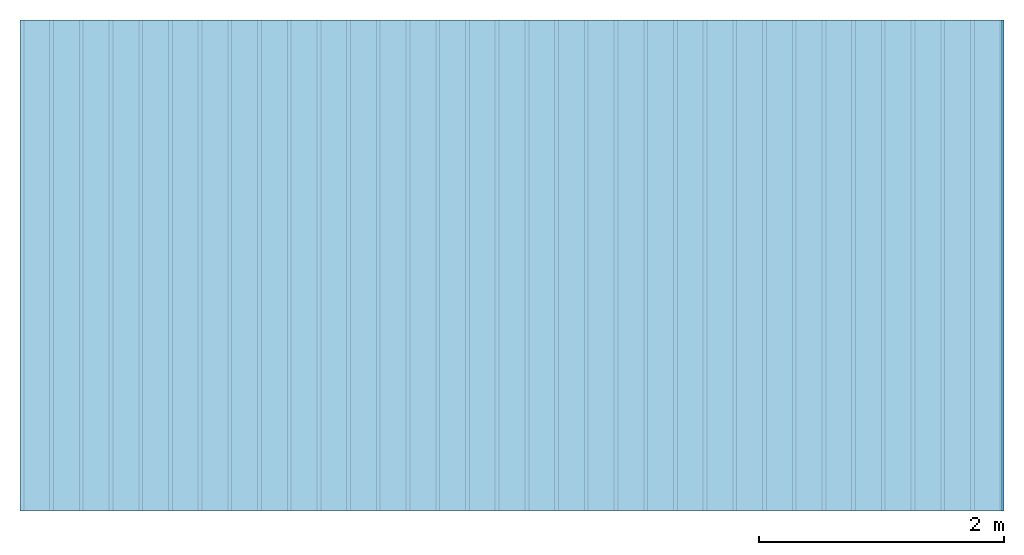
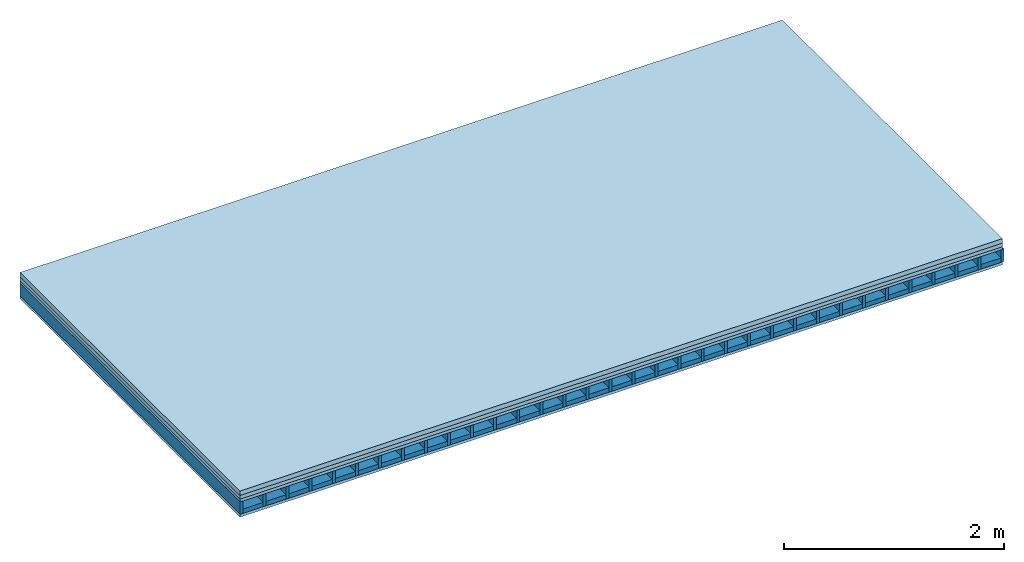
# One storey: 4 plates, 2 members, 1 element without a shape of its own.
"""IFC4 building model written with IfcOpenShell, lengths in metres."""

from ifc_helpers import new_model, si_unit, derived_unit, direction, frame, frame_2d, origin, origin_with_axes, place, context, project, spatial, rectangle, extrude, material, layer, layer_set, type_object, element, aggregate, save


model = new_model("IFC4")

# Units and contexts
plan_context = context("Plan", 3, precision=1e-05, world=origin(), true_north=direction((0.0, 1.0)))
model_context = context("Model", 3, precision=1e-05, world=origin(), true_north=direction((0.0, 1.0)))
ifc_project = project(units=[si_unit("LENGTHUNIT", "METRE"), derived_unit("SOUNDPRESSUREUNIT", [(si_unit("PRESSUREUNIT", "PASCAL", prefix="MICRO"), 0)]), si_unit("ENERGYUNIT", "JOULE", prefix="MEGA"), si_unit("MASSUNIT", "GRAM", prefix="KILO"), derived_unit("THERMALTRANSMITTANCEUNIT", [(si_unit("POWERUNIT", "WATT"), 1), (si_unit("AREAUNIT", "SQUARE_METRE"), -1), (si_unit("THERMODYNAMICTEMPERATUREUNIT", "KELVIN"), -1)]), derived_unit("AREADENSITYUNIT", [(si_unit("MASSUNIT", "GRAM", prefix="KILO"), 1), (si_unit("AREAUNIT", "SQUARE_METRE"), -1)]), derived_unit("USERDEFINED", [(si_unit("ENERGYUNIT", "JOULE", prefix="MEGA"), 1), (si_unit("AREAUNIT", "SQUARE_METRE"), -1)])], contexts=[plan_context, model_context])

# Site, building, storey
site = spatial("IfcSite", under=ifc_project)
building_placement = place(None, origin())
building = spatial("IfcBuilding", under=site, at=building_placement)
storey_placement = place(building_placement, origin())
storey = spatial("IfcBuildingStorey", under=building, at=storey_placement)

# Slab, members, plates
ifc_material_1 = material(Name="Cement screed", Category="04.006")
ifc_layer_1 = layer(ifc_material_1, 0.05, Name="On-material")
ifc_material_2 = material(Name="EP1, 40/35mm")
ifc_layer_2 = layer(ifc_material_2, 0.04, Name="Impact sound insulation")
ifc_material_3 = material(Name="surface element sheathing above")
ifc_layer_3 = layer(ifc_material_3, 0.031, Name="Sub-floor")
ifc_layer_4 = layer(None, 0.138, Name="Supporting structure")
ifc_material_4 = material(Name="surface element sheathing below")
ifc_layer_5 = layer(ifc_material_4, 0.031, Name="Lower layer 1")
ifc_layer_set = layer_set([ifc_layer_1, ifc_layer_2, ifc_layer_3, ifc_layer_4, ifc_layer_5])
slab_type = type_object("IfcSlabType", Name="A2705", PredefinedType="NOTDEFINED", material=ifc_layer_set)
slab_placement = place(None, frame((0.0, 0.0, 0.0), z_axis=(0.0, 0.0, -1.0), x_axis=(1.0, 0.0, 0.0)))
slab = element("IfcSlab", 1, at=slab_placement, inside=storey, type_object=slab_type, material=ifc_layer_set, Name="Slab #1")
ifc_material_5 = material(Name="surface element LFE")
member_1_placement = place(slab_placement, origin())
member_1 = element("IfcMember", 2, at=member_1_placement, material=ifc_material_5, Name="Supporting structure", context=plan_context, shape_type="SweptSolid", body=[
    extrude(rectangle(XDim=0.031, YDim=0.138, at=frame_2d((0.0155, 0.069), x_axis=(1.0, 0.0))), frame((0.0, 4.0, 0.121), z_axis=(0.0, -1.0, 0.0), x_axis=(1.0, 0.0, 0.0)), (0.0, 0.0, 1.0), 4.0),
    extrude(rectangle(XDim=0.031, YDim=0.138, at=frame_2d((0.0155, 0.069), x_axis=(1.0, 0.0))), frame((0.242, 4.0, 0.121), z_axis=(0.0, -1.0, 0.0), x_axis=(1.0, 0.0, 0.0)), (0.0, 0.0, 1.0), 4.0),
    extrude(rectangle(XDim=0.031, YDim=0.138, at=frame_2d((0.0155, 0.069), x_axis=(1.0, 0.0))), frame((0.484, 4.0, 0.121), z_axis=(0.0, -1.0, 0.0), x_axis=(1.0, 0.0, 0.0)), (0.0, 0.0, 1.0), 4.0),
    extrude(rectangle(XDim=0.031, YDim=0.138, at=frame_2d((0.0155, 0.069), x_axis=(1.0, 0.0))), frame((0.726, 4.0, 0.121), z_axis=(0.0, -1.0, 0.0), x_axis=(1.0, 0.0, 0.0)), (0.0, 0.0, 1.0), 4.0),
    extrude(rectangle(XDim=0.031, YDim=0.138, at=frame_2d((0.0155, 0.069), x_axis=(1.0, 0.0))), frame((0.968, 4.0, 0.121), z_axis=(0.0, -1.0, 0.0), x_axis=(1.0, 0.0, 0.0)), (0.0, 0.0, 1.0), 4.0),
    extrude(rectangle(XDim=0.031, YDim=0.138, at=frame_2d((0.0155, 0.069), x_axis=(1.0, 0.0))), frame((1.21, 4.0, 0.121), z_axis=(0.0, -1.0, 0.0), x_axis=(1.0, 0.0, 0.0)), (0.0, 0.0, 1.0), 4.0),
    extrude(rectangle(XDim=0.031, YDim=0.138, at=frame_2d((0.0155, 0.069), x_axis=(1.0, 0.0))), frame((1.452, 4.0, 0.121), z_axis=(0.0, -1.0, 0.0), x_axis=(1.0, 0.0, 0.0)), (0.0, 0.0, 1.0), 4.0),
    extrude(rectangle(XDim=0.031, YDim=0.138, at=frame_2d((0.0155, 0.069), x_axis=(1.0, 0.0))), frame((1.694, 4.0, 0.121), z_axis=(0.0, -1.0, 0.0), x_axis=(1.0, 0.0, 0.0)), (0.0, 0.0, 1.0), 4.0),
    extrude(rectangle(XDim=0.031, YDim=0.138, at=frame_2d((0.0155, 0.069), x_axis=(1.0, 0.0))), frame((1.936, 4.0, 0.121), z_axis=(0.0, -1.0, 0.0), x_axis=(1.0, 0.0, 0.0)), (0.0, 0.0, 1.0), 4.0),
    extrude(rectangle(XDim=0.031, YDim=0.138, at=frame_2d((0.0155, 0.069), x_axis=(1.0, 0.0))), frame((2.178, 4.0, 0.121), z_axis=(0.0, -1.0, 0.0), x_axis=(1.0, 0.0, 0.0)), (0.0, 0.0, 1.0), 4.0),
    extrude(rectangle(XDim=0.031, YDim=0.138, at=frame_2d((0.0155, 0.069), x_axis=(1.0, 0.0))), frame((2.42, 4.0, 0.121), z_axis=(0.0, -1.0, 0.0), x_axis=(1.0, 0.0, 0.0)), (0.0, 0.0, 1.0), 4.0),
    extrude(rectangle(XDim=0.031, YDim=0.138, at=frame_2d((0.0155, 0.069), x_axis=(1.0, 0.0))), frame((2.662, 4.0, 0.121), z_axis=(0.0, -1.0, 0.0), x_axis=(1.0, 0.0, 0.0)), (0.0, 0.0, 1.0), 4.0),
    extrude(rectangle(XDim=0.031, YDim=0.138, at=frame_2d((0.0155, 0.069), x_axis=(1.0, 0.0))), frame((2.904, 4.0, 0.121), z_axis=(0.0, -1.0, 0.0), x_axis=(1.0, 0.0, 0.0)), (0.0, 0.0, 1.0), 4.0),
    extrude(rectangle(XDim=0.031, YDim=0.138, at=frame_2d((0.0155, 0.069), x_axis=(1.0, 0.0))), frame((3.146, 4.0, 0.121), z_axis=(0.0, -1.0, 0.0), x_axis=(1.0, 0.0, 0.0)), (0.0, 0.0, 1.0), 4.0),
    extrude(rectangle(XDim=0.031, YDim=0.138, at=frame_2d((0.0155, 0.069), x_axis=(1.0, 0.0))), frame((3.388, 4.0, 0.121), z_axis=(0.0, -1.0, 0.0), x_axis=(1.0, 0.0, 0.0)), (0.0, 0.0, 1.0), 4.0),
    extrude(rectangle(XDim=0.031, YDim=0.138, at=frame_2d((0.0155, 0.069), x_axis=(1.0, 0.0))), frame((3.63, 4.0, 0.121), z_axis=(0.0, -1.0, 0.0), x_axis=(1.0, 0.0, 0.0)), (0.0, 0.0, 1.0), 4.0),
    extrude(rectangle(XDim=0.031, YDim=0.138, at=frame_2d((0.0155, 0.069), x_axis=(1.0, 0.0))), frame((3.872, 4.0, 0.121), z_axis=(0.0, -1.0, 0.0), x_axis=(1.0, 0.0, 0.0)), (0.0, 0.0, 1.0), 4.0),
    extrude(rectangle(XDim=0.031, YDim=0.138, at=frame_2d((0.0155, 0.069), x_axis=(1.0, 0.0))), frame((4.114, 4.0, 0.121), z_axis=(0.0, -1.0, 0.0), x_axis=(1.0, 0.0, 0.0)), (0.0, 0.0, 1.0), 4.0),
    extrude(rectangle(XDim=0.031, YDim=0.138, at=frame_2d((0.0155, 0.069), x_axis=(1.0, 0.0))), frame((4.356, 4.0, 0.121), z_axis=(0.0, -1.0, 0.0), x_axis=(1.0, 0.0, 0.0)), (0.0, 0.0, 1.0), 4.0),
    extrude(rectangle(XDim=0.031, YDim=0.138, at=frame_2d((0.0155, 0.069), x_axis=(1.0, 0.0))), frame((4.598, 4.0, 0.121), z_axis=(0.0, -1.0, 0.0), x_axis=(1.0, 0.0, 0.0)), (0.0, 0.0, 1.0), 4.0),
    extrude(rectangle(XDim=0.031, YDim=0.138, at=frame_2d((0.0155, 0.069), x_axis=(1.0, 0.0))), frame((4.84, 4.0, 0.121), z_axis=(0.0, -1.0, 0.0), x_axis=(1.0, 0.0, 0.0)), (0.0, 0.0, 1.0), 4.0),
    extrude(rectangle(XDim=0.031, YDim=0.138, at=frame_2d((0.0155, 0.069), x_axis=(1.0, 0.0))), frame((5.082, 4.0, 0.121), z_axis=(0.0, -1.0, 0.0), x_axis=(1.0, 0.0, 0.0)), (0.0, 0.0, 1.0), 4.0),
    extrude(rectangle(XDim=0.031, YDim=0.138, at=frame_2d((0.0155, 0.069), x_axis=(1.0, 0.0))), frame((5.324, 4.0, 0.121), z_axis=(0.0, -1.0, 0.0), x_axis=(1.0, 0.0, 0.0)), (0.0, 0.0, 1.0), 4.0),
    extrude(rectangle(XDim=0.031, YDim=0.138, at=frame_2d((0.0155, 0.069), x_axis=(1.0, 0.0))), frame((5.566, 4.0, 0.121), z_axis=(0.0, -1.0, 0.0), x_axis=(1.0, 0.0, 0.0)), (0.0, 0.0, 1.0), 4.0),
    extrude(rectangle(XDim=0.031, YDim=0.138, at=frame_2d((0.0155, 0.069), x_axis=(1.0, 0.0))), frame((5.808, 4.0, 0.121), z_axis=(0.0, -1.0, 0.0), x_axis=(1.0, 0.0, 0.0)), (0.0, 0.0, 1.0), 4.0),
    extrude(rectangle(XDim=0.031, YDim=0.138, at=frame_2d((0.0155, 0.069), x_axis=(1.0, 0.0))), frame((6.05, 4.0, 0.121), z_axis=(0.0, -1.0, 0.0), x_axis=(1.0, 0.0, 0.0)), (0.0, 0.0, 1.0), 4.0),
    extrude(rectangle(XDim=0.031, YDim=0.138, at=frame_2d((0.0155, 0.069), x_axis=(1.0, 0.0))), frame((6.292, 4.0, 0.121), z_axis=(0.0, -1.0, 0.0), x_axis=(1.0, 0.0, 0.0)), (0.0, 0.0, 1.0), 4.0),
    extrude(rectangle(XDim=0.031, YDim=0.138, at=frame_2d((0.0155, 0.069), x_axis=(1.0, 0.0))), frame((6.534, 4.0, 0.121), z_axis=(0.0, -1.0, 0.0), x_axis=(1.0, 0.0, 0.0)), (0.0, 0.0, 1.0), 4.0),
    extrude(rectangle(XDim=0.031, YDim=0.138, at=frame_2d((0.0155, 0.069), x_axis=(1.0, 0.0))), frame((6.776, 4.0, 0.121), z_axis=(0.0, -1.0, 0.0), x_axis=(1.0, 0.0, 0.0)), (0.0, 0.0, 1.0), 4.0),
    extrude(rectangle(XDim=0.031, YDim=0.138, at=frame_2d((0.0155, 0.069), x_axis=(1.0, 0.0))), frame((7.018, 4.0, 0.121), z_axis=(0.0, -1.0, 0.0), x_axis=(1.0, 0.0, 0.0)), (0.0, 0.0, 1.0), 4.0),
    extrude(rectangle(XDim=0.031, YDim=0.138, at=frame_2d((0.0155, 0.069), x_axis=(1.0, 0.0))), frame((7.26, 4.0, 0.121), z_axis=(0.0, -1.0, 0.0), x_axis=(1.0, 0.0, 0.0)), (0.0, 0.0, 1.0), 4.0),
    extrude(rectangle(XDim=0.031, YDim=0.138, at=frame_2d((0.0155, 0.069), x_axis=(1.0, 0.0))), frame((7.502, 4.0, 0.121), z_axis=(0.0, -1.0, 0.0), x_axis=(1.0, 0.0, 0.0)), (0.0, 0.0, 1.0), 4.0),
    extrude(rectangle(XDim=0.031, YDim=0.138, at=frame_2d((0.0155, 0.069), x_axis=(1.0, 0.0))), frame((7.744, 4.0, 0.121), z_axis=(0.0, -1.0, 0.0), x_axis=(1.0, 0.0, 0.0)), (0.0, 0.0, 1.0), 4.0),
    extrude(rectangle(XDim=0.031, YDim=0.138, at=frame_2d((0.0155, 0.069), x_axis=(1.0, 0.0))), frame((7.986, 4.0, 0.121), z_axis=(0.0, -1.0, 0.0), x_axis=(1.0, 0.0, 0.0)), (0.0, 0.0, 1.0), 4.0),
])
ifc_material_6 = material()
member_2_placement = place(slab_placement, origin())
member_2 = element("IfcMember", 3, at=member_2_placement, material=ifc_material_6, Name="in supporting structure", context=plan_context, shape_type="SweptSolid", body=[
    extrude(rectangle(XDim=0.211, YDim=0.049, at=frame_2d((0.1055, 0.0245), x_axis=(1.0, 0.0))), frame((0.031, 4.0, 0.21), z_axis=(0.0, -1.0, 0.0), x_axis=(1.0, 0.0, 0.0)), (0.0, 0.0, 1.0), 4.0),
    extrude(rectangle(XDim=0.211, YDim=0.049, at=frame_2d((0.1055, 0.0245), x_axis=(1.0, 0.0))), frame((0.273, 4.0, 0.21), z_axis=(0.0, -1.0, 0.0), x_axis=(1.0, 0.0, 0.0)), (0.0, 0.0, 1.0), 4.0),
    extrude(rectangle(XDim=0.211, YDim=0.049, at=frame_2d((0.1055, 0.0245), x_axis=(1.0, 0.0))), frame((0.515, 4.0, 0.21), z_axis=(0.0, -1.0, 0.0), x_axis=(1.0, 0.0, 0.0)), (0.0, 0.0, 1.0), 4.0),
    extrude(rectangle(XDim=0.211, YDim=0.049, at=frame_2d((0.1055, 0.0245), x_axis=(1.0, 0.0))), frame((0.757, 4.0, 0.21), z_axis=(0.0, -1.0, 0.0), x_axis=(1.0, 0.0, 0.0)), (0.0, 0.0, 1.0), 4.0),
    extrude(rectangle(XDim=0.211, YDim=0.049, at=frame_2d((0.1055, 0.0245), x_axis=(1.0, 0.0))), frame((0.999, 4.0, 0.21), z_axis=(0.0, -1.0, 0.0), x_axis=(1.0, 0.0, 0.0)), (0.0, 0.0, 1.0), 4.0),
    extrude(rectangle(XDim=0.211, YDim=0.049, at=frame_2d((0.1055, 0.0245), x_axis=(1.0, 0.0))), frame((1.241, 4.0, 0.21), z_axis=(0.0, -1.0, 0.0), x_axis=(1.0, 0.0, 0.0)), (0.0, 0.0, 1.0), 4.0),
    extrude(rectangle(XDim=0.211, YDim=0.049, at=frame_2d((0.1055, 0.0245), x_axis=(1.0, 0.0))), frame((1.483, 4.0, 0.21), z_axis=(0.0, -1.0, 0.0), x_axis=(1.0, 0.0, 0.0)), (0.0, 0.0, 1.0), 4.0),
    extrude(rectangle(XDim=0.211, YDim=0.049, at=frame_2d((0.1055, 0.0245), x_axis=(1.0, 0.0))), frame((1.725, 4.0, 0.21), z_axis=(0.0, -1.0, 0.0), x_axis=(1.0, 0.0, 0.0)), (0.0, 0.0, 1.0), 4.0),
    extrude(rectangle(XDim=0.211, YDim=0.049, at=frame_2d((0.1055, 0.0245), x_axis=(1.0, 0.0))), frame((1.967, 4.0, 0.21), z_axis=(0.0, -1.0, 0.0), x_axis=(1.0, 0.0, 0.0)), (0.0, 0.0, 1.0), 4.0),
    extrude(rectangle(XDim=0.211, YDim=0.049, at=frame_2d((0.1055, 0.0245), x_axis=(1.0, 0.0))), frame((2.209, 4.0, 0.21), z_axis=(0.0, -1.0, 0.0), x_axis=(1.0, 0.0, 0.0)), (0.0, 0.0, 1.0), 4.0),
    extrude(rectangle(XDim=0.211, YDim=0.049, at=frame_2d((0.1055, 0.0245), x_axis=(1.0, 0.0))), frame((2.451, 4.0, 0.21), z_axis=(0.0, -1.0, 0.0), x_axis=(1.0, 0.0, 0.0)), (0.0, 0.0, 1.0), 4.0),
    extrude(rectangle(XDim=0.211, YDim=0.049, at=frame_2d((0.1055, 0.0245), x_axis=(1.0, 0.0))), frame((2.693, 4.0, 0.21), z_axis=(0.0, -1.0, 0.0), x_axis=(1.0, 0.0, 0.0)), (0.0, 0.0, 1.0), 4.0),
    extrude(rectangle(XDim=0.211, YDim=0.049, at=frame_2d((0.1055, 0.0245), x_axis=(1.0, 0.0))), frame((2.935, 4.0, 0.21), z_axis=(0.0, -1.0, 0.0), x_axis=(1.0, 0.0, 0.0)), (0.0, 0.0, 1.0), 4.0),
    extrude(rectangle(XDim=0.211, YDim=0.049, at=frame_2d((0.1055, 0.0245), x_axis=(1.0, 0.0))), frame((3.177, 4.0, 0.21), z_axis=(0.0, -1.0, 0.0), x_axis=(1.0, 0.0, 0.0)), (0.0, 0.0, 1.0), 4.0),
    extrude(rectangle(XDim=0.211, YDim=0.049, at=frame_2d((0.1055, 0.0245), x_axis=(1.0, 0.0))), frame((3.419, 4.0, 0.21), z_axis=(0.0, -1.0, 0.0), x_axis=(1.0, 0.0, 0.0)), (0.0, 0.0, 1.0), 4.0),
    extrude(rectangle(XDim=0.211, YDim=0.049, at=frame_2d((0.1055, 0.0245), x_axis=(1.0, 0.0))), frame((3.661, 4.0, 0.21), z_axis=(0.0, -1.0, 0.0), x_axis=(1.0, 0.0, 0.0)), (0.0, 0.0, 1.0), 4.0),
    extrude(rectangle(XDim=0.211, YDim=0.049, at=frame_2d((0.1055, 0.0245), x_axis=(1.0, 0.0))), frame((3.903, 4.0, 0.21), z_axis=(0.0, -1.0, 0.0), x_axis=(1.0, 0.0, 0.0)), (0.0, 0.0, 1.0), 4.0),
    extrude(rectangle(XDim=0.211, YDim=0.049, at=frame_2d((0.1055, 0.0245), x_axis=(1.0, 0.0))), frame((4.145, 4.0, 0.21), z_axis=(0.0, -1.0, 0.0), x_axis=(1.0, 0.0, 0.0)), (0.0, 0.0, 1.0), 4.0),
    extrude(rectangle(XDim=0.211, YDim=0.049, at=frame_2d((0.1055, 0.0245), x_axis=(1.0, 0.0))), frame((4.387, 4.0, 0.21), z_axis=(0.0, -1.0, 0.0), x_axis=(1.0, 0.0, 0.0)), (0.0, 0.0, 1.0), 4.0),
    extrude(rectangle(XDim=0.211, YDim=0.049, at=frame_2d((0.1055, 0.0245), x_axis=(1.0, 0.0))), frame((4.629, 4.0, 0.21), z_axis=(0.0, -1.0, 0.0), x_axis=(1.0, 0.0, 0.0)), (0.0, 0.0, 1.0), 4.0),
    extrude(rectangle(XDim=0.211, YDim=0.049, at=frame_2d((0.1055, 0.0245), x_axis=(1.0, 0.0))), frame((4.871, 4.0, 0.21), z_axis=(0.0, -1.0, 0.0), x_axis=(1.0, 0.0, 0.0)), (0.0, 0.0, 1.0), 4.0),
    extrude(rectangle(XDim=0.211, YDim=0.049, at=frame_2d((0.1055, 0.0245), x_axis=(1.0, 0.0))), frame((5.113, 4.0, 0.21), z_axis=(0.0, -1.0, 0.0), x_axis=(1.0, 0.0, 0.0)), (0.0, 0.0, 1.0), 4.0),
    extrude(rectangle(XDim=0.211, YDim=0.049, at=frame_2d((0.1055, 0.0245), x_axis=(1.0, 0.0))), frame((5.355, 4.0, 0.21), z_axis=(0.0, -1.0, 0.0), x_axis=(1.0, 0.0, 0.0)), (0.0, 0.0, 1.0), 4.0),
    extrude(rectangle(XDim=0.211, YDim=0.049, at=frame_2d((0.1055, 0.0245), x_axis=(1.0, 0.0))), frame((5.597, 4.0, 0.21), z_axis=(0.0, -1.0, 0.0), x_axis=(1.0, 0.0, 0.0)), (0.0, 0.0, 1.0), 4.0),
    extrude(rectangle(XDim=0.211, YDim=0.049, at=frame_2d((0.1055, 0.0245), x_axis=(1.0, 0.0))), frame((5.839, 4.0, 0.21), z_axis=(0.0, -1.0, 0.0), x_axis=(1.0, 0.0, 0.0)), (0.0, 0.0, 1.0), 4.0),
    extrude(rectangle(XDim=0.211, YDim=0.049, at=frame_2d((0.1055, 0.0245), x_axis=(1.0, 0.0))), frame((6.081, 4.0, 0.21), z_axis=(0.0, -1.0, 0.0), x_axis=(1.0, 0.0, 0.0)), (0.0, 0.0, 1.0), 4.0),
    extrude(rectangle(XDim=0.211, YDim=0.049, at=frame_2d((0.1055, 0.0245), x_axis=(1.0, 0.0))), frame((6.323, 4.0, 0.21), z_axis=(0.0, -1.0, 0.0), x_axis=(1.0, 0.0, 0.0)), (0.0, 0.0, 1.0), 4.0),
    extrude(rectangle(XDim=0.211, YDim=0.049, at=frame_2d((0.1055, 0.0245), x_axis=(1.0, 0.0))), frame((6.565, 4.0, 0.21), z_axis=(0.0, -1.0, 0.0), x_axis=(1.0, 0.0, 0.0)), (0.0, 0.0, 1.0), 4.0),
    extrude(rectangle(XDim=0.211, YDim=0.049, at=frame_2d((0.1055, 0.0245), x_axis=(1.0, 0.0))), frame((6.807, 4.0, 0.21), z_axis=(0.0, -1.0, 0.0), x_axis=(1.0, 0.0, 0.0)), (0.0, 0.0, 1.0), 4.0),
    extrude(rectangle(XDim=0.211, YDim=0.049, at=frame_2d((0.1055, 0.0245), x_axis=(1.0, 0.0))), frame((7.049, 4.0, 0.21), z_axis=(0.0, -1.0, 0.0), x_axis=(1.0, 0.0, 0.0)), (0.0, 0.0, 1.0), 4.0),
    extrude(rectangle(XDim=0.211, YDim=0.049, at=frame_2d((0.1055, 0.0245), x_axis=(1.0, 0.0))), frame((7.291, 4.0, 0.21), z_axis=(0.0, -1.0, 0.0), x_axis=(1.0, 0.0, 0.0)), (0.0, 0.0, 1.0), 4.0),
    extrude(rectangle(XDim=0.211, YDim=0.049, at=frame_2d((0.1055, 0.0245), x_axis=(1.0, 0.0))), frame((7.533, 4.0, 0.21), z_axis=(0.0, -1.0, 0.0), x_axis=(1.0, 0.0, 0.0)), (0.0, 0.0, 1.0), 4.0),
    extrude(rectangle(XDim=0.211, YDim=0.049, at=frame_2d((0.1055, 0.0245), x_axis=(1.0, 0.0))), frame((7.775, 4.0, 0.21), z_axis=(0.0, -1.0, 0.0), x_axis=(1.0, 0.0, 0.0)), (0.0, 0.0, 1.0), 4.0),
])
plate_1_placement = place(slab_placement, origin())
plate_1 = element("IfcPlate", 4, at=plate_1_placement, material=ifc_material_1, Name="On-material", context=plan_context, shape_type="SweptSolid", body=[
    extrude(rectangle(XDim=8.0, YDim=4.0, at=frame_2d((4.0, 2.0), x_axis=(1.0, 0.0))), origin_with_axes(), (0.0, 0.0, 1.0), 0.05),
])
plate_2_placement = place(slab_placement, origin())
plate_2 = element("IfcPlate", 5, at=plate_2_placement, material=ifc_material_2, Name="Impact sound insulation", context=plan_context, shape_type="SweptSolid", body=[
    extrude(rectangle(XDim=8.0, YDim=4.0, at=frame_2d((4.0, 2.0), x_axis=(1.0, 0.0))), frame((0.0, 0.0, 0.05), z_axis=(0.0, 0.0, 1.0), x_axis=(1.0, 0.0, 0.0)), (0.0, 0.0, 1.0), 0.04),
])
plate_3_placement = place(slab_placement, origin())
plate_3 = element("IfcPlate", 6, at=plate_3_placement, material=ifc_material_3, Name="Sub-floor", context=plan_context, shape_type="SweptSolid", body=[
    extrude(rectangle(XDim=8.0, YDim=4.0, at=frame_2d((4.0, 2.0), x_axis=(1.0, 0.0))), frame((0.0, 0.0, 0.09), z_axis=(0.0, 0.0, 1.0), x_axis=(1.0, 0.0, 0.0)), (0.0, 0.0, 1.0), 0.031),
])
plate_4_placement = place(slab_placement, origin())
plate_4 = element("IfcPlate", 7, at=plate_4_placement, material=ifc_material_4, Name="Lower layer 1", context=plan_context, shape_type="SweptSolid", body=[
    extrude(rectangle(XDim=8.0, YDim=4.0, at=frame_2d((4.0, 2.0), x_axis=(1.0, 0.0))), frame((0.0, 0.0, 0.259), z_axis=(0.0, 0.0, 1.0), x_axis=(1.0, 0.0, 0.0)), (0.0, 0.0, 1.0), 0.031),
])
aggregate(slab, [plate_1, plate_2, plate_3, member_1, member_2, plate_4])

save(model, "model.ifc")
